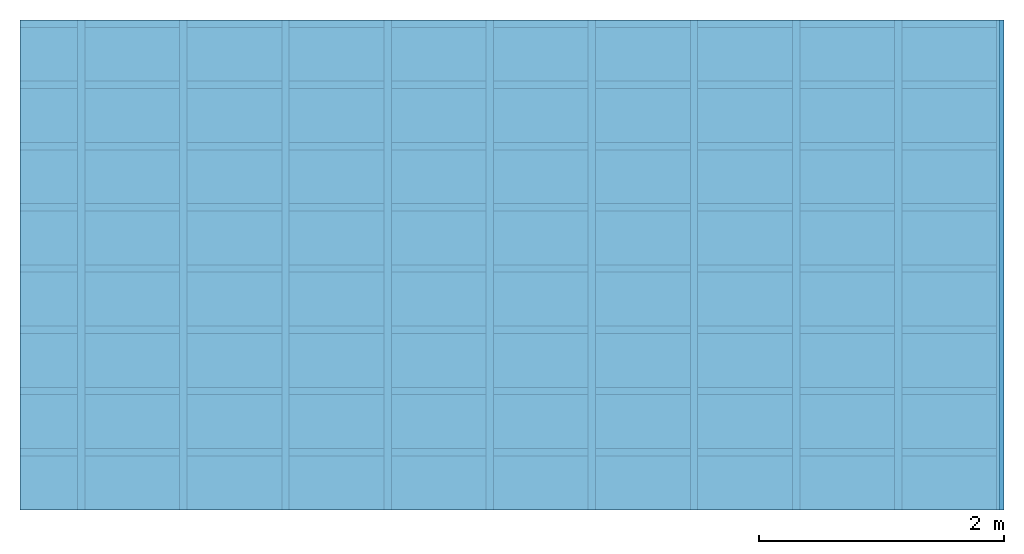
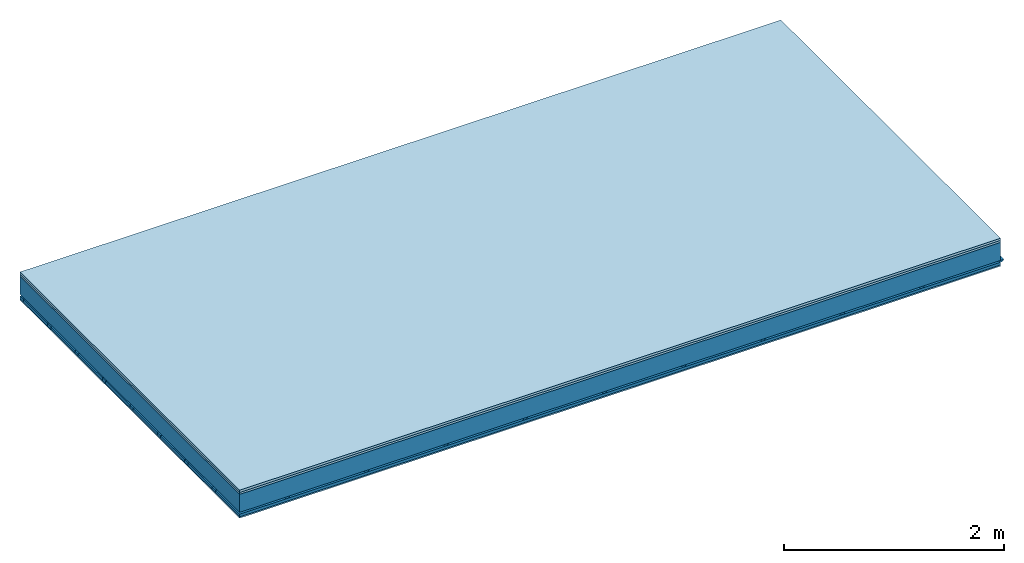
# One storey: 4 members, 3 plates, 1 element without a shape of its own.
"""IFC4 building model written with IfcOpenShell, lengths in metres."""

import ifcopenshell
import ifcopenshell.guid

model = None  # the IFC model being written
_history = None  # IfcOwnerHistory: only IFC2X3 demands one
_inside = {}  # id of a spatial element -> (the spatial element, [elements in it])
_under = {}  # id of a project, library or spatial element -> (it, [spatial elements below it])
_declared = {}  # id of a project -> (the project, [libraries it declares])
_typed = {}  # id of a type object -> (the type object, [elements of that type])
_made_of = {}  # id of a material, layer set ... -> (it, [elements and type objects made of it])


def new_model(schema):
    """Start an empty IFC model of exactly this schema.

    Asked for "IFC4X3", IfcOpenShell would pick the latest addendum, in which some entities
    have other attributes; the version numbers below select the first issue.
    IFC2X3 requires an IfcOwnerHistory on every rooted entity: one is made here for all.
    """
    global model, _history
    if schema == "IFC4X3":
        model = ifcopenshell.file(schema_version=(4, 3, 0, 0))
    else:
        model = ifcopenshell.file(schema=schema)
    _inside.clear()
    _under.clear()
    _declared.clear()
    _typed.clear()
    _made_of.clear()
    _history = None
    if model.schema == "IFC2X3":
        org = make("IfcOrganization", Name="unknown")
        user = make(
            "IfcPersonAndOrganization",
            ThePerson=make("IfcPerson", FamilyName="unknown"),
            TheOrganization=org,
        )
        app = make(
            "IfcApplication",
            ApplicationDeveloper=org,
            Version="unknown",
            ApplicationFullName="unknown",
            ApplicationIdentifier="unknown",
        )
        _history = make(
            "IfcOwnerHistory",
            OwningUser=user,
            OwningApplication=app,
            ChangeAction="ADDED",
            CreationDate=0,
        )
    return model


def make(cls, **values):
    """One entity of the class cls with the attributes given. An attribute that is None is left unset."""
    return model.create_entity(
        cls, **{name: value for name, value in values.items() if value is not None}
    )


def rooted(cls, **values):
    """An entity with a GlobalId (a new one), such as an element, a storey or a relation."""
    return make(cls, GlobalId=ifcopenshell.guid.new(), OwnerHistory=_history, **values)


def si_unit(unit_type, name, prefix=None):
    """IfcSIUnit, for example si_unit("LENGTHUNIT", "METRE", prefix="MILLI")."""
    return make("IfcSIUnit", UnitType=unit_type, Prefix=prefix, Name=name)


def derived_unit(unit_type, elements):
    """IfcDerivedUnit: a product of units, each with its exponent."""
    return make(
        "IfcDerivedUnit",
        Elements=[
            make("IfcDerivedUnitElement", Unit=unit, Exponent=power)
            for unit, power in elements
        ],
        UnitType=unit_type,
    )


def assignment(units):
    """IfcUnitAssignment: the units of a project."""
    return None if units is None else make("IfcUnitAssignment", Units=units)


def point(xyz):
    """IfcCartesianPoint."""
    return None if xyz is None else make("IfcCartesianPoint", Coordinates=xyz)


def direction(xyz):
    """IfcDirection."""
    return None if xyz is None else make("IfcDirection", DirectionRatios=xyz)


def frame(location, z_axis=None, x_axis=None):
    """IfcAxis2Placement3D, a coordinate frame: its origin and axes. An axis left out is left unset."""
    return make(
        "IfcAxis2Placement3D",
        Location=point(location),
        Axis=direction(z_axis),
        RefDirection=direction(x_axis),
    )


def frame_2d(location, x_axis=None):
    """IfcAxis2Placement2D, a coordinate frame in the plane: its origin and x axis."""
    return make(
        "IfcAxis2Placement2D", Location=point(location), RefDirection=direction(x_axis)
    )


def origin():
    """The frame at (0, 0, 0) with its axes left unset."""
    return frame((0.0, 0.0, 0.0))


def origin_with_axes():
    """The frame at (0, 0, 0) with the z axis (0, 0, 1) and the x axis (1, 0, 0) written out."""
    return frame((0.0, 0.0, 0.0), z_axis=(0.0, 0.0, 1.0), x_axis=(1.0, 0.0, 0.0))


def place(relative_to, where):
    """IfcLocalPlacement: puts the frame where relative to a parent placement (None: the world)."""
    return make(
        "IfcLocalPlacement", PlacementRelTo=relative_to, RelativePlacement=where
    )


def context(
    kind, dimensions, precision=None, world=None, true_north=None, identifier=None
):
    """IfcGeometricRepresentationContext, for example the 3D "Model" context."""
    return make(
        "IfcGeometricRepresentationContext",
        ContextIdentifier=identifier,
        ContextType=kind,
        CoordinateSpaceDimension=dimensions,
        Precision=precision,
        WorldCoordinateSystem=world,
        TrueNorth=true_north,
    )


def project(units=None, contexts=None):
    """IfcProject with its units and contexts."""
    return rooted(
        "IfcProject",
        Name="project",
        RepresentationContexts=contexts,
        UnitsInContext=assignment(units),
    )


def spatial(cls, under=None, at=None, **own):
    """A site, building, storey or space (cls), placed at a placement, below another one or the project."""
    s = rooted(cls, ObjectPlacement=at, **own)
    if under is not None:
        _under.setdefault(under.id(), (under, []))[1].append(s)
    return s


def polyline(points):
    """IfcPolyline through the points."""
    return make("IfcPolyline", Points=[point(p) for p in points])


def profile(cls, at=None, kind="AREA", **sizes):
    """A parametric profile (cls). Its sizes go by their IFC names, for example OverallWidth=200.0."""
    return make(cls, ProfileType=kind, Position=at, **sizes)


def rectangle(**sizes):
    """IfcRectangleProfileDef."""
    return profile("IfcRectangleProfileDef", **sizes)


def outline(outer, holes=None, kind="AREA"):
    """IfcArbitraryClosedProfileDef: a profile drawn as a closed curve; with holes, ...WithVoids."""
    if holes is None:
        return make("IfcArbitraryClosedProfileDef", ProfileType=kind, OuterCurve=outer)
    return make(
        "IfcArbitraryProfileDefWithVoids",
        ProfileType=kind,
        OuterCurve=outer,
        InnerCurves=holes,
    )


def extrude(swept, where, along, depth):
    """IfcExtrudedAreaSolid: the profile swept, set in the frame where, extruded along a direction by depth."""
    return make(
        "IfcExtrudedAreaSolid",
        SweptArea=swept,
        Position=where,
        ExtrudedDirection=direction(along),
        Depth=depth,
    )


def shape(context_of_items, identifier, shape_type, items):
    """IfcShapeRepresentation: the items that make up one representation, for example the "Body"."""
    return make(
        "IfcShapeRepresentation",
        ContextOfItems=context_of_items,
        RepresentationIdentifier=identifier,
        RepresentationType=shape_type,
        Items=items,
    )


def material(Name=None, Category=None):
    """IfcMaterial."""
    return make("IfcMaterial", Name=Name, Category=Category)


def layer(
    of_material, thickness, ventilated=None, Name=None, Category=None, Priority=None
):
    """IfcMaterialLayer: one layer of a wall or slab, of a material (None: an air gap)."""
    return make(
        "IfcMaterialLayer",
        Material=of_material,
        LayerThickness=thickness,
        IsVentilated=ventilated,
        Name=Name,
        Category=Category,
        Priority=Priority,
    )


def layer_set(layers, Name=None):
    """IfcMaterialLayerSet."""
    return make("IfcMaterialLayerSet", MaterialLayers=layers, LayerSetName=Name)


def made_of(thing, what):
    """Note that an element or type object is made of a material, layer set ...; save() writes the relation."""
    if what is not None:
        _made_of.setdefault(what.id(), (what, []))[1].append(thing)
    return thing


def type_object(cls, material=None, **own):
    """A type object (cls), such as IfcWallType, which elements share."""
    return made_of(rooted(cls, **own), material)


def element(
    cls,
    number,
    at=None,
    inside=None,
    cuts=None,
    type_object=None,
    material=None,
    context=None,
    identifier="Body",
    shape_type=None,
    held_by="IfcProductDefinitionShape",
    body=None,
    shapes=None,
    **own,
):
    """One element of the class cls, such as IfcWall. Its Tag is "e" and its number.

    at: its placement. inside: the storey or other place that contains it. cuts: it is an
    opening in that element (IfcRelVoidsElement). A single representation is given by context,
    identifier, shape_type and body (its items); several are given by shapes. held_by: the class
    of the entity that holds the representations. save() writes the other relations.
    """
    e = rooted(cls, Tag="e%d" % number, ObjectPlacement=at, **own)
    if body is not None:
        shapes = [shape(context, identifier, shape_type, body)]
    if shapes is not None:
        e.Representation = make(held_by, Representations=shapes)
    if inside is not None:
        _inside.setdefault(inside.id(), (inside, []))[1].append(e)
    if cuts is not None:
        rooted(
            "IfcRelVoidsElement", RelatingBuildingElement=cuts, RelatedOpeningElement=e
        )
    if type_object is not None:
        _typed.setdefault(type_object.id(), (type_object, []))[1].append(e)
    return made_of(e, material)


def aggregate(whole, parts):
    """IfcRelAggregates: a whole, such as a stair, and the parts it consists of."""
    return rooted("IfcRelAggregates", RelatingObject=whole, RelatedObjects=parts)


def save(model, path):
    """Write the relations noted so far, then the file.

    IfcRelAggregates (storeys below a building ...), IfcRelContainedInSpatialStructure (elements
    in a storey), IfcRelDefinesByType, IfcRelAssociatesMaterial and IfcRelDeclares: one each for
    every whole, place, type object, material and project.
    """
    for whole, parts in _under.values():
        aggregate(whole, parts)
    for where, things in _inside.values():
        rooted(
            "IfcRelContainedInSpatialStructure",
            RelatedElements=things,
            RelatingStructure=where,
        )
    for kind, things in _typed.values():
        rooted("IfcRelDefinesByType", RelatedObjects=things, RelatingType=kind)
    for what, things in _made_of.values():
        rooted("IfcRelAssociatesMaterial", RelatedObjects=things, RelatingMaterial=what)
    for by, libraries in _declared.values():
        rooted("IfcRelDeclares", RelatingContext=by, RelatedDefinitions=libraries)
    model.write(path)


model = new_model("IFC4")

# Units and contexts
plan_context = context("Plan", 3, precision=1e-05, world=origin(), true_north=direction((0.0, 1.0)))
model_context = context("Model", 3, precision=1e-05, world=origin(), true_north=direction((0.0, 1.0)))
ifc_project = project(units=[si_unit("LENGTHUNIT", "METRE"), derived_unit("SOUNDPRESSUREUNIT", [(si_unit("PRESSUREUNIT", "PASCAL", prefix="MICRO"), 0)]), si_unit("ENERGYUNIT", "JOULE", prefix="MEGA"), si_unit("MASSUNIT", "GRAM", prefix="KILO"), derived_unit("THERMALTRANSMITTANCEUNIT", [(si_unit("POWERUNIT", "WATT"), 1), (si_unit("AREAUNIT", "SQUARE_METRE"), -1), (si_unit("THERMODYNAMICTEMPERATUREUNIT", "KELVIN"), -1)]), derived_unit("AREADENSITYUNIT", [(si_unit("MASSUNIT", "GRAM", prefix="KILO"), 1), (si_unit("AREAUNIT", "SQUARE_METRE"), -1)]), derived_unit("USERDEFINED", [(si_unit("ENERGYUNIT", "JOULE", prefix="MEGA"), 1), (si_unit("AREAUNIT", "SQUARE_METRE"), -1)])], contexts=[plan_context, model_context])

# Site, building, storey
site = spatial("IfcSite", under=ifc_project)
building_placement = place(None, origin())
building = spatial("IfcBuilding", under=site, at=building_placement)
storey_placement = place(building_placement, origin())
storey = spatial("IfcBuildingStorey", under=building, at=storey_placement)

# Slab, members, plates
ifc_material_1 = material(Name="Floor heating system Therm38 longitudinal", Category="03.007")
ifc_layer_1 = layer(ifc_material_1, 0.025, Name="On-material")
ifc_material_2 = material(Category="10.009")
ifc_layer_2 = layer(ifc_material_2, 0.022, Name="Impact sound insulation")
ifc_layer_3 = layer(None, 0.2, Name="Supporting structure")
ifc_material_3 = material(Name="no composite action")
ifc_layer_4 = layer(ifc_material_3, 0.0, Name="Bond")
ifc_layer_5 = layer(None, 0.02, Name="Coupling")
ifc_layer_6 = layer(None, 0.03, Name="Battens / profiles")
ifc_material_4 = material(Category="03.007")
ifc_layer_7 = layer(ifc_material_4, 0.015, Name="Ceiling covering 1st layer")
ifc_material_5 = material(Name="Glued joints")
ifc_layer_8 = layer(ifc_material_5, 0.0, Name="Surface / treatment")
ifc_layer_set = layer_set([ifc_layer_1, ifc_layer_2, ifc_layer_3, ifc_layer_4, ifc_layer_5, ifc_layer_6, ifc_layer_7, ifc_layer_8])
slab_type = type_object("IfcSlabType", Name="A0866", PredefinedType="NOTDEFINED", material=ifc_layer_set)
slab_placement = place(None, frame((0.0, 0.0, 0.0), z_axis=(0.0, 0.0, -1.0), x_axis=(1.0, 0.0, 0.0)))
slab = element("IfcSlab", 1, at=slab_placement, inside=storey, type_object=slab_type, material=ifc_layer_set, Name="Slab #1")
ifc_material_6 = material()
member_1_placement = place(slab_placement, origin())
member_1 = element("IfcMember", 2, at=member_1_placement, material=ifc_material_6, Name="Supporting structure", context=plan_context, shape_type="SweptSolid", body=[
    extrude(rectangle(XDim=1.0, YDim=0.2, at=frame_2d((0.5, 0.1), x_axis=(1.0, 0.0))), frame((0.0, 4.0, 0.047), z_axis=(0.0, -1.0, 0.0), x_axis=(1.0, 0.0, 0.0)), (0.0, 0.0, 1.0), 4.0),
    extrude(rectangle(XDim=1.0, YDim=0.2, at=frame_2d((0.5, 0.1), x_axis=(1.0, 0.0))), frame((1.0, 4.0, 0.047), z_axis=(0.0, -1.0, 0.0), x_axis=(1.0, 0.0, 0.0)), (0.0, 0.0, 1.0), 4.0),
    extrude(rectangle(XDim=1.0, YDim=0.2, at=frame_2d((0.5, 0.1), x_axis=(1.0, 0.0))), frame((2.0, 4.0, 0.047), z_axis=(0.0, -1.0, 0.0), x_axis=(1.0, 0.0, 0.0)), (0.0, 0.0, 1.0), 4.0),
    extrude(rectangle(XDim=1.0, YDim=0.2, at=frame_2d((0.5, 0.1), x_axis=(1.0, 0.0))), frame((3.0, 4.0, 0.047), z_axis=(0.0, -1.0, 0.0), x_axis=(1.0, 0.0, 0.0)), (0.0, 0.0, 1.0), 4.0),
    extrude(rectangle(XDim=1.0, YDim=0.2, at=frame_2d((0.5, 0.1), x_axis=(1.0, 0.0))), frame((4.0, 4.0, 0.047), z_axis=(0.0, -1.0, 0.0), x_axis=(1.0, 0.0, 0.0)), (0.0, 0.0, 1.0), 4.0),
    extrude(rectangle(XDim=1.0, YDim=0.2, at=frame_2d((0.5, 0.1), x_axis=(1.0, 0.0))), frame((5.0, 4.0, 0.047), z_axis=(0.0, -1.0, 0.0), x_axis=(1.0, 0.0, 0.0)), (0.0, 0.0, 1.0), 4.0),
    extrude(rectangle(XDim=1.0, YDim=0.2, at=frame_2d((0.5, 0.1), x_axis=(1.0, 0.0))), frame((6.0, 4.0, 0.047), z_axis=(0.0, -1.0, 0.0), x_axis=(1.0, 0.0, 0.0)), (0.0, 0.0, 1.0), 4.0),
    extrude(rectangle(XDim=1.0, YDim=0.2, at=frame_2d((0.5, 0.1), x_axis=(1.0, 0.0))), frame((7.0, 4.0, 0.047), z_axis=(0.0, -1.0, 0.0), x_axis=(1.0, 0.0, 0.0)), (0.0, 0.0, 1.0), 4.0),
])
ifc_material_7 = material()
member_2_placement = place(slab_placement, origin())
member_2 = element("IfcMember", 3, at=member_2_placement, material=ifc_material_7, Name="Coupling", context=plan_context, shape_type="SweptSolid", body=[
    extrude(outline(polyline([(0.0, 0.0), (0.06, 0.0), (0.04, 0.02), (0.02, 0.02), (0.0, 0.0)])), frame((0.47, 4.0, 0.247), z_axis=(0.0, -1.0, 0.0), x_axis=(1.0, 0.0, 0.0)), (0.0, 0.0, 1.0), 4.0),
    extrude(outline(polyline([(0.0, 0.0), (0.06, 0.0), (0.04, 0.02), (0.02, 0.02), (0.0, 0.0)])), frame((1.304, 4.0, 0.247), z_axis=(0.0, -1.0, 0.0), x_axis=(1.0, 0.0, 0.0)), (0.0, 0.0, 1.0), 4.0),
    extrude(outline(polyline([(0.0, 0.0), (0.06, 0.0), (0.04, 0.02), (0.02, 0.02), (0.0, 0.0)])), frame((2.138, 4.0, 0.247), z_axis=(0.0, -1.0, 0.0), x_axis=(1.0, 0.0, 0.0)), (0.0, 0.0, 1.0), 4.0),
    extrude(outline(polyline([(0.0, 0.0), (0.06, 0.0), (0.04, 0.02), (0.02, 0.02), (0.0, 0.0)])), frame((2.972, 4.0, 0.247), z_axis=(0.0, -1.0, 0.0), x_axis=(1.0, 0.0, 0.0)), (0.0, 0.0, 1.0), 4.0),
    extrude(outline(polyline([(0.0, 0.0), (0.06, 0.0), (0.04, 0.02), (0.02, 0.02), (0.0, 0.0)])), frame((3.806, 4.0, 0.247), z_axis=(0.0, -1.0, 0.0), x_axis=(1.0, 0.0, 0.0)), (0.0, 0.0, 1.0), 4.0),
    extrude(outline(polyline([(0.0, 0.0), (0.06, 0.0), (0.04, 0.02), (0.02, 0.02), (0.0, 0.0)])), frame((4.64, 4.0, 0.247), z_axis=(0.0, -1.0, 0.0), x_axis=(1.0, 0.0, 0.0)), (0.0, 0.0, 1.0), 4.0),
    extrude(outline(polyline([(0.0, 0.0), (0.06, 0.0), (0.04, 0.02), (0.02, 0.02), (0.0, 0.0)])), frame((5.474, 4.0, 0.247), z_axis=(0.0, -1.0, 0.0), x_axis=(1.0, 0.0, 0.0)), (0.0, 0.0, 1.0), 4.0),
    extrude(outline(polyline([(0.0, 0.0), (0.06, 0.0), (0.04, 0.02), (0.02, 0.02), (0.0, 0.0)])), frame((6.308, 4.0, 0.247), z_axis=(0.0, -1.0, 0.0), x_axis=(1.0, 0.0, 0.0)), (0.0, 0.0, 1.0), 4.0),
    extrude(outline(polyline([(0.0, 0.0), (0.06, 0.0), (0.04, 0.02), (0.02, 0.02), (0.0, 0.0)])), frame((7.142, 4.0, 0.247), z_axis=(0.0, -1.0, 0.0), x_axis=(1.0, 0.0, 0.0)), (0.0, 0.0, 1.0), 4.0),
    extrude(outline(polyline([(0.0, 0.0), (0.06, 0.0), (0.04, 0.02), (0.02, 0.02), (0.0, 0.0)])), frame((7.976, 4.0, 0.247), z_axis=(0.0, -1.0, 0.0), x_axis=(1.0, 0.0, 0.0)), (0.0, 0.0, 1.0), 4.0),
])
ifc_material_8 = material()
member_3_placement = place(slab_placement, origin())
member_3 = element("IfcMember", 4, at=member_3_placement, material=ifc_material_8, Name="Battens / profiles", context=plan_context, shape_type="SweptSolid", body=[
    extrude(rectangle(XDim=0.06, YDim=0.03, at=frame_2d((0.03, 0.015), x_axis=(1.0, 0.0))), frame((0.0, 0.0, 0.267), z_axis=(1.0, 0.0, 0.0), x_axis=(0.0, 1.0, 0.0)), (0.0, 0.0, 1.0), 8.0),
    extrude(rectangle(XDim=0.06, YDim=0.03, at=frame_2d((0.03, 0.015), x_axis=(1.0, 0.0))), frame((0.0, 0.5, 0.267), z_axis=(1.0, 0.0, 0.0), x_axis=(0.0, 1.0, 0.0)), (0.0, 0.0, 1.0), 8.0),
    extrude(rectangle(XDim=0.06, YDim=0.03, at=frame_2d((0.03, 0.015), x_axis=(1.0, 0.0))), frame((0.0, 1.0, 0.267), z_axis=(1.0, 0.0, 0.0), x_axis=(0.0, 1.0, 0.0)), (0.0, 0.0, 1.0), 8.0),
    extrude(rectangle(XDim=0.06, YDim=0.03, at=frame_2d((0.03, 0.015), x_axis=(1.0, 0.0))), frame((0.0, 1.5, 0.267), z_axis=(1.0, 0.0, 0.0), x_axis=(0.0, 1.0, 0.0)), (0.0, 0.0, 1.0), 8.0),
    extrude(rectangle(XDim=0.06, YDim=0.03, at=frame_2d((0.03, 0.015), x_axis=(1.0, 0.0))), frame((0.0, 2.0, 0.267), z_axis=(1.0, 0.0, 0.0), x_axis=(0.0, 1.0, 0.0)), (0.0, 0.0, 1.0), 8.0),
    extrude(rectangle(XDim=0.06, YDim=0.03, at=frame_2d((0.03, 0.015), x_axis=(1.0, 0.0))), frame((0.0, 2.5, 0.267), z_axis=(1.0, 0.0, 0.0), x_axis=(0.0, 1.0, 0.0)), (0.0, 0.0, 1.0), 8.0),
    extrude(rectangle(XDim=0.06, YDim=0.03, at=frame_2d((0.03, 0.015), x_axis=(1.0, 0.0))), frame((0.0, 3.0, 0.267), z_axis=(1.0, 0.0, 0.0), x_axis=(0.0, 1.0, 0.0)), (0.0, 0.0, 1.0), 8.0),
    extrude(rectangle(XDim=0.06, YDim=0.03, at=frame_2d((0.03, 0.015), x_axis=(1.0, 0.0))), frame((0.0, 3.5, 0.267), z_axis=(1.0, 0.0, 0.0), x_axis=(0.0, 1.0, 0.0)), (0.0, 0.0, 1.0), 8.0),
])
ifc_material_9 = material()
member_4_placement = place(slab_placement, origin())
member_4 = element("IfcMember", 5, at=member_4_placement, material=ifc_material_9, Name="Cavity", context=plan_context, shape_type="SweptSolid", body=[
    extrude(rectangle(XDim=0.44, YDim=0.03, at=frame_2d((0.22, 0.015), x_axis=(1.0, 0.0))), frame((0.0, 0.06, 0.267), z_axis=(1.0, 0.0, 0.0), x_axis=(0.0, 1.0, 0.0)), (0.0, 0.0, 1.0), 8.0),
    extrude(rectangle(XDim=0.44, YDim=0.03, at=frame_2d((0.22, 0.015), x_axis=(1.0, 0.0))), frame((0.0, 0.56, 0.267), z_axis=(1.0, 0.0, 0.0), x_axis=(0.0, 1.0, 0.0)), (0.0, 0.0, 1.0), 8.0),
    extrude(rectangle(XDim=0.44, YDim=0.03, at=frame_2d((0.22, 0.015), x_axis=(1.0, 0.0))), frame((0.0, 1.06, 0.267), z_axis=(1.0, 0.0, 0.0), x_axis=(0.0, 1.0, 0.0)), (0.0, 0.0, 1.0), 8.0),
    extrude(rectangle(XDim=0.44, YDim=0.03, at=frame_2d((0.22, 0.015), x_axis=(1.0, 0.0))), frame((0.0, 1.56, 0.267), z_axis=(1.0, 0.0, 0.0), x_axis=(0.0, 1.0, 0.0)), (0.0, 0.0, 1.0), 8.0),
    extrude(rectangle(XDim=0.44, YDim=0.03, at=frame_2d((0.22, 0.015), x_axis=(1.0, 0.0))), frame((0.0, 2.06, 0.267), z_axis=(1.0, 0.0, 0.0), x_axis=(0.0, 1.0, 0.0)), (0.0, 0.0, 1.0), 8.0),
    extrude(rectangle(XDim=0.44, YDim=0.03, at=frame_2d((0.22, 0.015), x_axis=(1.0, 0.0))), frame((0.0, 2.56, 0.267), z_axis=(1.0, 0.0, 0.0), x_axis=(0.0, 1.0, 0.0)), (0.0, 0.0, 1.0), 8.0),
    extrude(rectangle(XDim=0.44, YDim=0.03, at=frame_2d((0.22, 0.015), x_axis=(1.0, 0.0))), frame((0.0, 3.06, 0.267), z_axis=(1.0, 0.0, 0.0), x_axis=(0.0, 1.0, 0.0)), (0.0, 0.0, 1.0), 8.0),
    extrude(rectangle(XDim=0.44, YDim=0.03, at=frame_2d((0.22, 0.015), x_axis=(1.0, 0.0))), frame((0.0, 3.56, 0.267), z_axis=(1.0, 0.0, 0.0), x_axis=(0.0, 1.0, 0.0)), (0.0, 0.0, 1.0), 8.0),
])
plate_1_placement = place(slab_placement, origin())
plate_1 = element("IfcPlate", 6, at=plate_1_placement, material=ifc_material_1, Name="On-material", context=plan_context, shape_type="SweptSolid", body=[
    extrude(rectangle(XDim=8.0, YDim=4.0, at=frame_2d((4.0, 2.0), x_axis=(1.0, 0.0))), origin_with_axes(), (0.0, 0.0, 1.0), 0.025),
])
plate_2_placement = place(slab_placement, origin())
plate_2 = element("IfcPlate", 7, at=plate_2_placement, material=ifc_material_2, Name="Impact sound insulation", context=plan_context, shape_type="SweptSolid", body=[
    extrude(rectangle(XDim=8.0, YDim=4.0, at=frame_2d((4.0, 2.0), x_axis=(1.0, 0.0))), frame((0.0, 0.0, 0.025), z_axis=(0.0, 0.0, 1.0), x_axis=(1.0, 0.0, 0.0)), (0.0, 0.0, 1.0), 0.022),
])
plate_3_placement = place(slab_placement, origin())
plate_3 = element("IfcPlate", 8, at=plate_3_placement, material=ifc_material_4, Name="Ceiling covering 1st layer", context=plan_context, shape_type="SweptSolid", body=[
    extrude(rectangle(XDim=8.0, YDim=4.0, at=frame_2d((4.0, 2.0), x_axis=(1.0, 0.0))), frame((0.0, 0.0, 0.297), z_axis=(0.0, 0.0, 1.0), x_axis=(1.0, 0.0, 0.0)), (0.0, 0.0, 1.0), 0.015),
])
aggregate(slab, [plate_1, plate_2, member_1, member_2, member_3, member_4, plate_3])

save(model, "model.ifc")
